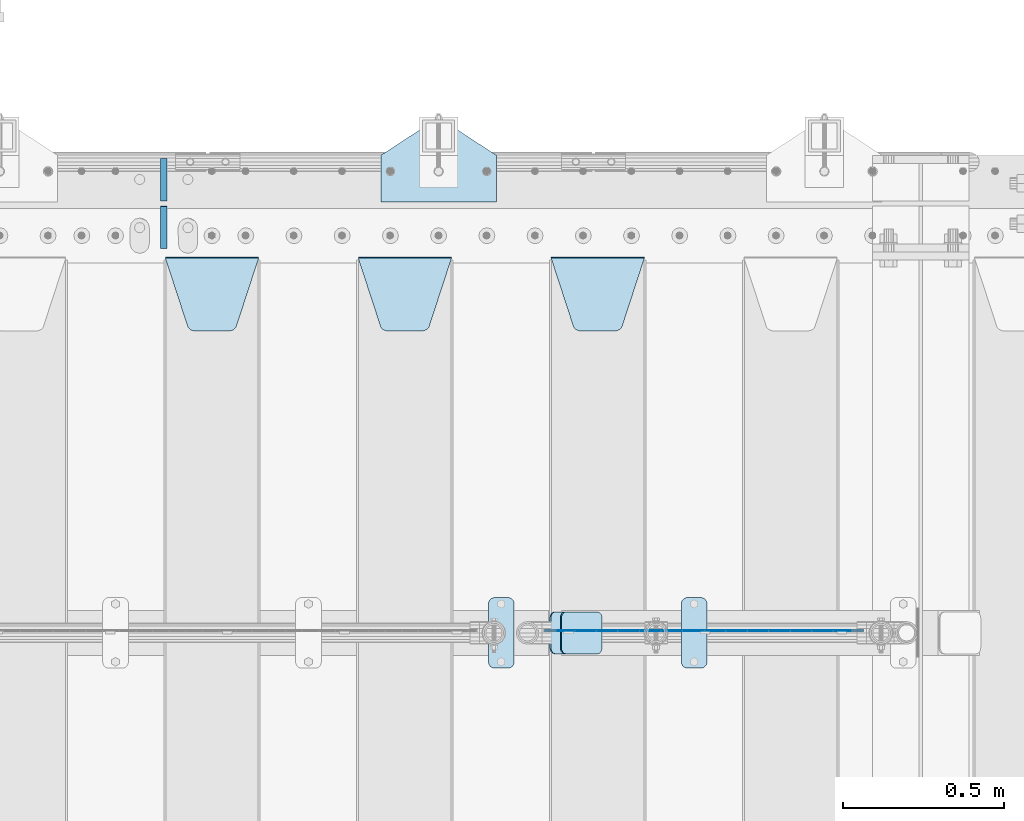
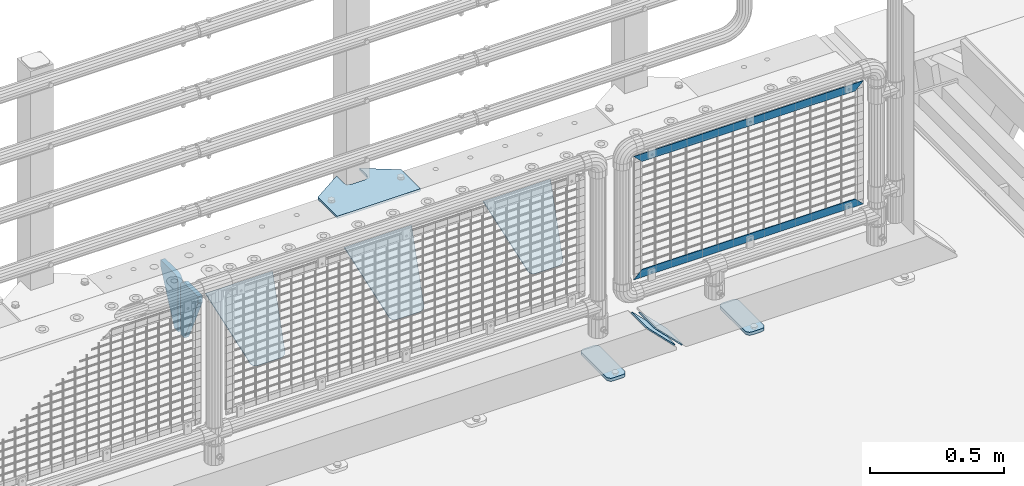
# One storey, part 202 of 219: 12 plates.
"""IFC2X3 building model written with IfcOpenShell, lengths in millimetres."""

from ifc_helpers import new_model, si_unit, frame, origin_with_axes, place, context, subcontext, project, spatial, faceted_brep, material, type_object, element, save


model = new_model("IFC2X3")

# Units and contexts
model_context = context("Model", 3, precision=1e-05, world=origin_with_axes())
body_context = subcontext(model_context, "Body", "Model", "MODEL_VIEW")
ifc_project = project(units=[si_unit("LENGTHUNIT", "METRE", prefix="MILLI"), si_unit("AREAUNIT", "SQUARE_METRE"), si_unit("VOLUMEUNIT", "CUBIC_METRE"), si_unit("MASSUNIT", "GRAM", prefix="KILO"), si_unit("TIMEUNIT", "SECOND"), si_unit("PLANEANGLEUNIT", "RADIAN"), si_unit("SOLIDANGLEUNIT", "STERADIAN"), si_unit("THERMODYNAMICTEMPERATUREUNIT", "DEGREE_CELSIUS"), si_unit("LUMINOUSINTENSITYUNIT", "LUMEN")], contexts=[model_context])

# Site, building, storey
site_placement = place(None, origin_with_axes())
site = spatial("IfcSite", under=ifc_project, at=site_placement, CompositionType="ELEMENT")
building_placement = place(site_placement, origin_with_axes())
building = spatial("IfcBuilding", under=site, at=building_placement, Name="Standard", CompositionType="ELEMENT")
storey_placement = place(building_placement, origin_with_axes())
storey = spatial("IfcBuildingStorey", under=building, at=storey_placement, Name="Undefined", CompositionType="ELEMENT", Elevation=0.0)

# Plates
ifc_material_1 = material(Name="STEEL/S355N")
plate_type_1 = type_object("IfcPlateType", PredefinedType="NOTDEFINED")
plate_1_placement = place(storey_placement, frame((12405.0, 32831.767766956, -1.76776695296758), z_axis=(0.0, -0.707106781186547, -0.707106781186548), x_axis=(1.0, 0.0, 0.0)))
element("IfcPlate", 1, at=plate_1_placement, inside=storey, type_object=plate_type_1, material=ifc_material_1, context=body_context, shape_type="Brep", body=[
    faceted_brep([(0.0, -2.5, 0.0), (69.345504679477, -2.5, 300.171731424834), (69.345504679477, 2.49999999999636, 300.171731424831), (0.0, 2.5, 0.0), (70.9274061199576, -2.50000000000364, 304.8974424154), (70.9274061199576, 2.49999999999636, 304.8974424154), (73.3818627772307, -2.50000000000364, 309.234538108532), (73.3818627772307, 2.49999999999636, 309.234538108532), (76.6187032999569, -2.50000000000364, 313.023683126106), (76.6187032999569, 2.49999999999636, 313.023683126106), (80.5190132704993, -2.50000000000364, 316.125672595372), (80.5190132704993, 2.49999999999636, 316.125672595372), (84.9395038596831, -2.50000000000364, 318.426546230476), (84.9395038596831, 2.5, 318.426546230479), (89.7177759439237, -2.50000000000364, 319.841774983277), (89.7177759439237, 2.5, 319.841774983281), (94.6782862926502, -2.50000000000364, 320.319366455078), (94.6782862926502, 2.49999999999636, 320.319366455078), (195.32171370735, -2.50000000000364, 320.319366455078), (195.32171370735, 2.49999999999636, 320.319366455078), (200.282224056076, -2.50000000000364, 319.841774983277), (200.282224056076, 2.5, 319.841774983281), (205.060496140317, -2.50000000000364, 318.426546230476), (205.060496140317, 2.49999999999636, 318.426546230476), (209.480986729501, -2.50000000000364, 316.125672595372), (209.480986729501, 2.49999999999636, 316.125672595372), (213.381296700043, -2.50000000000364, 313.023683126106), (213.381296700043, 2.49999999999272, 313.023683126106), (216.618137222769, -2.50000000000364, 309.234538108529), (216.618137222769, 2.49999999999636, 309.234538108525), (219.072593880042, -2.50000000000364, 304.8974424154), (219.072593880042, 2.49999999999636, 304.8974424154), (220.654495320523, -2.5, 300.171731424834), (220.654495320523, 2.49999999999636, 300.171731424831), (290.0, -2.50000000000364, 3.63797880709171e-12), (290.0, 2.49999999999636, 0.0)], [[[0, 1, 2, 3]], [[1, 4, 5, 2]], [[4, 6, 7, 5]], [[6, 8, 9, 7]], [[8, 10, 11, 9]], [[10, 12, 13, 11]], [[12, 14, 15, 13]], [[14, 16, 17, 15]], [[16, 18, 19, 17]], [[18, 20, 21, 19]], [[20, 22, 23, 21]], [[22, 24, 25, 23]], [[24, 26, 27, 25]], [[26, 28, 29, 27]], [[28, 30, 31, 29]], [[30, 32, 33, 31]], [[32, 34, 35, 33]], [[34, 0, 3, 35]], [[5, 7, 9, 11, 13, 15, 17, 19, 21, 23, 25, 27, 29, 31, 33, 35, 3, 2]], [[34, 32, 30, 28, 26, 24, 22, 20, 18, 16, 14, 12, 10, 8, 6, 4, 1, 0]]]),
])
plate_2_placement = place(storey_placement, frame((11805.0, 32831.767766956, -1.76776695296758), z_axis=(0.0, -0.707106781186547, -0.707106781186548), x_axis=(1.0, 0.0, 0.0)))
element("IfcPlate", 2, at=plate_2_placement, inside=storey, type_object=plate_type_1, material=ifc_material_1, context=body_context, shape_type="Brep", body=[
    faceted_brep([(0.0, -2.5, 0.0), (69.345504679477, -2.5, 300.171731424834), (69.345504679477, 2.49999999999636, 300.171731424831), (0.0, 2.5, 0.0), (70.9274061199576, -2.50000000000364, 304.8974424154), (70.9274061199576, 2.49999999999636, 304.8974424154), (73.3818627772307, -2.50000000000364, 309.234538108532), (73.3818627772307, 2.49999999999636, 309.234538108532), (76.6187032999569, -2.50000000000364, 313.023683126106), (76.6187032999569, 2.49999999999636, 313.023683126106), (80.5190132704993, -2.50000000000364, 316.125672595372), (80.5190132704993, 2.49999999999636, 316.125672595372), (84.9395038596831, -2.50000000000364, 318.426546230476), (84.9395038596831, 2.5, 318.426546230479), (89.7177759439237, -2.50000000000364, 319.841774983277), (89.7177759439237, 2.5, 319.841774983281), (94.6782862926502, -2.50000000000364, 320.319366455078), (94.6782862926502, 2.49999999999636, 320.319366455078), (195.32171370735, -2.50000000000364, 320.319366455078), (195.32171370735, 2.49999999999636, 320.319366455078), (200.282224056076, -2.50000000000364, 319.841774983277), (200.282224056076, 2.5, 319.841774983281), (205.060496140317, -2.50000000000364, 318.426546230476), (205.060496140317, 2.49999999999636, 318.426546230476), (209.480986729501, -2.50000000000364, 316.125672595372), (209.480986729501, 2.49999999999636, 316.125672595372), (213.381296700043, -2.50000000000364, 313.023683126106), (213.381296700043, 2.49999999999272, 313.023683126106), (216.618137222769, -2.50000000000364, 309.234538108529), (216.618137222769, 2.49999999999636, 309.234538108525), (219.072593880042, -2.50000000000364, 304.8974424154), (219.072593880042, 2.49999999999636, 304.8974424154), (220.654495320523, -2.5, 300.171731424834), (220.654495320523, 2.49999999999636, 300.171731424831), (290.0, -2.50000000000364, 3.63797880709171e-12), (290.0, 2.49999999999636, 0.0)], [[[0, 1, 2, 3]], [[1, 4, 5, 2]], [[4, 6, 7, 5]], [[6, 8, 9, 7]], [[8, 10, 11, 9]], [[10, 12, 13, 11]], [[12, 14, 15, 13]], [[14, 16, 17, 15]], [[16, 18, 19, 17]], [[18, 20, 21, 19]], [[20, 22, 23, 21]], [[22, 24, 25, 23]], [[24, 26, 27, 25]], [[26, 28, 29, 27]], [[28, 30, 31, 29]], [[30, 32, 33, 31]], [[32, 34, 35, 33]], [[34, 0, 3, 35]], [[5, 7, 9, 11, 13, 15, 17, 19, 21, 23, 25, 27, 29, 31, 33, 35, 3, 2]], [[34, 32, 30, 28, 26, 24, 22, 20, 18, 16, 14, 12, 10, 8, 6, 4, 1, 0]]]),
])
plate_3_placement = place(storey_placement, frame((11205.0, 32831.767766956, -1.76776695296758), z_axis=(0.0, -0.707106781186547, -0.707106781186548), x_axis=(1.0, 0.0, 0.0)))
element("IfcPlate", 3, at=plate_3_placement, inside=storey, type_object=plate_type_1, material=ifc_material_1, context=body_context, shape_type="Brep", body=[
    faceted_brep([(0.0, -2.5, 0.0), (69.345504679477, -2.5, 300.171731424834), (69.345504679477, 2.49999999999636, 300.171731424831), (0.0, 2.5, 0.0), (70.9274061199576, -2.50000000000364, 304.8974424154), (70.9274061199576, 2.49999999999636, 304.8974424154), (73.3818627772307, -2.50000000000364, 309.234538108532), (73.3818627772307, 2.49999999999636, 309.234538108532), (76.6187032999569, -2.50000000000364, 313.023683126106), (76.6187032999569, 2.49999999999636, 313.023683126106), (80.5190132704993, -2.50000000000364, 316.125672595372), (80.5190132704993, 2.49999999999636, 316.125672595372), (84.9395038596831, -2.50000000000364, 318.426546230476), (84.9395038596831, 2.5, 318.426546230479), (89.7177759439237, -2.50000000000364, 319.841774983277), (89.7177759439237, 2.5, 319.841774983281), (94.6782862926502, -2.50000000000364, 320.319366455078), (94.6782862926502, 2.49999999999636, 320.319366455078), (195.32171370735, -2.50000000000364, 320.319366455078), (195.32171370735, 2.49999999999636, 320.319366455078), (200.282224056076, -2.50000000000364, 319.841774983277), (200.282224056076, 2.5, 319.841774983281), (205.060496140317, -2.50000000000364, 318.426546230476), (205.060496140317, 2.49999999999636, 318.426546230476), (209.480986729501, -2.50000000000364, 316.125672595372), (209.480986729501, 2.49999999999636, 316.125672595372), (213.381296700043, -2.50000000000364, 313.023683126106), (213.381296700043, 2.49999999999272, 313.023683126106), (216.618137222769, -2.50000000000364, 309.234538108529), (216.618137222769, 2.49999999999636, 309.234538108525), (219.072593880042, -2.50000000000364, 304.8974424154), (219.072593880042, 2.49999999999636, 304.8974424154), (220.654495320523, -2.5, 300.171731424834), (220.654495320523, 2.49999999999636, 300.171731424831), (290.0, -2.50000000000364, 3.63797880709171e-12), (290.0, 2.49999999999636, 0.0)], [[[0, 1, 2, 3]], [[1, 4, 5, 2]], [[4, 6, 7, 5]], [[6, 8, 9, 7]], [[8, 10, 11, 9]], [[10, 12, 13, 11]], [[12, 14, 15, 13]], [[14, 16, 17, 15]], [[16, 18, 19, 17]], [[18, 20, 21, 19]], [[20, 22, 23, 21]], [[22, 24, 25, 23]], [[24, 26, 27, 25]], [[26, 28, 29, 27]], [[28, 30, 31, 29]], [[30, 32, 33, 31]], [[32, 34, 35, 33]], [[34, 0, 3, 35]], [[5, 7, 9, 11, 13, 15, 17, 19, 21, 23, 25, 27, 29, 31, 33, 35, 3, 2]], [[34, 32, 30, 28, 26, 24, 22, 20, 18, 16, 14, 12, 10, 8, 6, 4, 1, 0]]]),
])
ifc_material_2 = material(Name="Misc_Undefined")
plate_type_2 = type_object("IfcPlateType", PredefinedType="NOTDEFINED")
plate_4_placement = place(storey_placement, frame((12420.1100003336, 31670.4999883292, 386.520006105207), z_axis=(0.707106781186548, 0.0, -0.707106781186548), x_axis=(-0.707106781186548, 0.0, -0.707106781186548)))
element("IfcPlate", 4, at=plate_4_placement, inside=storey, type_object=plate_type_2, material=ifc_material_2, context=body_context, shape_type="Brep", body=[
    faceted_brep([(0.0, -1.5, -5.6843418860808e-14), (-651.52105712893, -1.5, 651.521179199219), (-651.521057128928, 1.49999999999636, 651.521179199219), (0.0, 1.5, -5.6843418860808e-14), (-651.52105712893, -1.5, 701.018676757811), (-651.521057128932, 1.5, 701.018676757811), (49.4974975585938, -1.5, 2.36468622460961e-11), (49.4974784851038, 1.5, -4.91127138957381e-11)], [[[0, 1, 2, 3]], [[1, 4, 5, 2]], [[4, 6, 7, 5]], [[6, 0, 3, 7]], [[5, 7, 3, 2]], [[6, 4, 1, 0]]]),
])
plate_5_placement = place(storey_placement, frame((13376.4999993967, 31670.4997837706, 914.520000514845), z_axis=(-0.707106781186548, 0.0, 0.707106781186548), x_axis=(-0.707106781186548, 0.0, -0.707106781186548)))
element("IfcPlate", 5, at=plate_5_placement, inside=storey, type_object=plate_type_2, material=ifc_material_2, context=body_context, shape_type="Brep", body=[
    faceted_brep([(0.0, -1.5, -5.6843418860808e-14), (701.018554687525, -1.50000000000728, 701.018615722655), (701.018554687524, 1.49999999999272, 701.018615722654), (0.0, 1.5, -5.6843418860808e-14), (701.018554687524, -1.50000000000728, 651.521118164063), (701.018554687524, 1.49999999999272, 651.521118164062), (49.4974975585938, -1.5, 2.36468622460961e-11), (49.4974784851038, 1.5, -4.91127138957381e-11)], [[[0, 1, 2, 3]], [[1, 4, 5, 2]], [[4, 6, 7, 5]], [[6, 0, 3, 7]], [[5, 7, 3, 2]], [[6, 4, 1, 0]]]),
])
plate_type_3 = type_object("IfcPlateType", PredefinedType="NOTDEFINED")
for number, where, z_axis, x_axis in (
    (6, (11200.0, 33140.0, -30.0), (0.0, 0.0, -1.0), (0.0, -1.0, 0.0)),
    (7, (11200.0, 32860.0, -30.0), (0.0, 0.0, -1.0), (0.0, 1.0, 0.0)),
):
    element("IfcPlate", number, at=place(storey_placement, frame(where, z_axis=z_axis, x_axis=x_axis)), inside=storey, type_object=plate_type_3, material=ifc_material_1, context=body_context, shape_type="Brep", body=[
        faceted_brep([(0.0, -10.0, 0.0), (0.0, -10.0, 30.0), (0.0, 10.0, 30.0), (0.0, 10.0, 0.0), (102.0, -10.0, 250.0), (102.0, 10.0, 250.0), (132.0, -10.0, 250.0), (132.0, 10.0, 250.0), (132.0, -10.0, 30.0), (132.0, 10.0, 30.0), (131.544232590368, -10.0, 24.790554669992), (131.544232590368, 10.0, 24.790554669992), (130.190778623579, -10.0, 19.7393957002299), (130.190778623579, 10.0, 19.7393957002299), (127.980762113533, -10.0, 15.0), (127.980762113533, 10.0, 15.0), (124.98133329357, -10.0, 10.7163717094038), (124.98133329357, 10.0, 10.7163717094038), (121.283628290596, -10.0, 7.01866670643062), (121.283628290596, 10.0, 7.01866670643062), (117.0, -10.0, 4.01923788646684), (117.0, 10.0, 4.01923788646684), (112.260604299769, -10.0, 1.80922137642278), (112.260604299769, 10.0, 1.80922137642278), (107.209445330009, -10.0, 0.455767409633722), (107.209445330009, 10.0, 0.455767409633722), (102.0, -10.0, 0.0), (102.0, 10.0, 0.0)], [[[0, 1, 2, 3]], [[1, 4, 5, 2]], [[4, 6, 7, 5]], [[6, 8, 9, 7]], [[8, 10, 11, 9]], [[10, 12, 13, 11]], [[12, 14, 15, 13]], [[14, 16, 17, 15]], [[16, 18, 19, 17]], [[18, 20, 21, 19]], [[20, 22, 23, 21]], [[22, 24, 25, 23]], [[24, 26, 27, 25]], [[26, 0, 3, 27]], [[5, 7, 9, 11, 13, 15, 17, 19, 21, 23, 25, 27, 3, 2]], [[26, 24, 22, 20, 18, 16, 14, 12, 10, 8, 6, 4, 1, 0]]]),
    ])
ifc_material_3 = material(Name="STEEL/S355J2")
plate_type_4 = type_object("IfcPlateType", PredefinedType="NOTDEFINED")
plate_6_placement = place(storey_placement, frame((12210.0, 31774.5, 21.0199999999977), z_axis=(1.0, 0.0, 0.0), x_axis=(0.0, -1.0, 0.0)))
element("IfcPlate", 8, at=plate_6_placement, inside=storey, type_object=plate_type_4, material=ifc_material_3, context=body_context, shape_type="Brep", body=[
    faceted_brep([(0.0, -7.0, 20.0), (0.0, -7.0, 60.0), (0.0, 7.0, 60.0), (0.0, 7.0, 20.0), (0.384294391937146, -7.0, 63.9018064403226), (0.384294391937146, 7.0, 63.9018064403226), (1.52240934977453, -7.0, 67.6536686473009), (1.52240934977453, 7.0, 67.6536686473009), (3.37060775395003, -7.0, 71.1114046603925), (3.37060775395003, 7.0, 71.1114046603925), (5.8578643762703, -7.0, 74.1421356237315), (5.8578643762703, 7.0, 74.1421356237315), (8.88859533960931, -7.0, 76.6293922460518), (8.88859533960931, 7.0, 76.6293922460518), (12.3463313526991, -7.0, 78.4775906502255), (12.3463313526991, 7.0, 78.4775906502255), (16.0981935596792, -7.0, 79.6157056080647), (16.0981935596792, 7.0, 79.6157056080647), (20.0, -7.0, 80.0), (20.0, 7.0, 80.0), (200.0, -7.0, 80.0), (200.0, 7.0, 80.0), (203.901806440321, -7.0, 79.6157056080647), (203.901806440321, 7.0, 79.6157056080647), (207.653668647301, -7.0, 78.4775906502255), (207.653668647301, 7.0, 78.4775906502255), (211.111404660391, -7.0, 76.6293922460518), (211.111404660391, 7.0, 76.6293922460518), (214.14213562373, -7.0, 74.1421356237315), (214.14213562373, 7.0, 74.1421356237315), (216.62939224605, -7.0, 71.1114046603925), (216.62939224605, 7.0, 71.1114046603925), (218.477590650225, -7.0, 67.6536686473009), (218.477590650225, 7.0, 67.6536686473009), (219.615705608063, -7.0, 63.9018064403226), (219.615705608063, 7.0, 63.9018064403226), (220.0, -7.0, 60.0), (220.0, 7.0, 60.0), (220.0, -7.0, 20.0), (220.0, 7.0, 20.0), (219.615705608063, -7.0, 16.0981935596774), (219.615705608063, 7.0, 16.0981935596774), (218.477590650225, -7.0, 12.3463313526991), (218.477590650225, 7.0, 12.3463313526991), (216.62939224605, -7.0, 8.88859533960749), (216.62939224605, 7.0, 8.88859533960749), (214.14213562373, -7.0, 5.85786437626848), (214.14213562373, 7.0, 5.85786437626848), (211.111404660391, -7.0, 3.37060775394821), (211.111404660391, 7.0, 3.37060775394821), (207.653668647301, -7.0, 1.52240934977453), (207.653668647301, 7.0, 1.52240934977453), (203.901806440321, -7.0, 0.384294391935327), (203.901806440321, 7.0, 0.384294391935327), (200.0, -7.0, 0.0), (200.0, 7.0, 0.0), (20.0, -7.0, 0.0), (20.0, 7.0, 0.0), (16.0981935596792, -7.0, 0.384294391935327), (16.0981935596792, 7.0, 0.384294391935327), (12.3463313526991, -7.0, 1.52240934977453), (12.3463313526991, 7.0, 1.52240934977453), (8.88859533960931, -7.0, 3.37060775394821), (8.88859533960931, 7.0, 3.37060775394821), (5.8578643762703, -7.0, 5.85786437626848), (5.8578643762703, 7.0, 5.85786437626848), (3.37060775395003, -7.0, 8.88859533960749), (3.37060775395003, 7.0, 8.88859533960749), (1.52240934977453, -7.0, 12.3463313526991), (1.52240934977453, 7.0, 12.3463313526991), (0.384294391937146, -7.0, 16.0981935596774), (0.384294391937146, 7.0, 16.0981935596774)], [[[0, 1, 2, 3]], [[1, 4, 5, 2]], [[4, 6, 7, 5]], [[6, 8, 9, 7]], [[8, 10, 11, 9]], [[10, 12, 13, 11]], [[12, 14, 15, 13]], [[14, 16, 17, 15]], [[16, 18, 19, 17]], [[18, 20, 21, 19]], [[20, 22, 23, 21]], [[22, 24, 25, 23]], [[24, 26, 27, 25]], [[26, 28, 29, 27]], [[28, 30, 31, 29]], [[30, 32, 33, 31]], [[32, 34, 35, 33]], [[34, 36, 37, 35]], [[36, 38, 39, 37]], [[38, 40, 41, 39]], [[40, 42, 43, 41]], [[42, 44, 45, 43]], [[44, 46, 47, 45]], [[46, 48, 49, 47]], [[48, 50, 51, 49]], [[50, 52, 53, 51]], [[52, 54, 55, 53]], [[54, 56, 57, 55]], [[56, 58, 59, 57]], [[58, 60, 61, 59]], [[60, 62, 63, 61]], [[62, 64, 65, 63]], [[64, 66, 67, 65]], [[66, 68, 69, 67]], [[68, 70, 71, 69]], [[70, 0, 3, 71]], [[5, 7, 9, 11, 13, 15, 17, 19, 21, 23, 25, 27, 29, 31, 33, 35, 37, 39, 41, 43, 45, 47, 49, 51, 53, 55, 57, 59, 61, 63, 65, 67, 69, 71, 3, 2]], [[70, 68, 66, 64, 62, 60, 58, 56, 54, 52, 50, 48, 46, 44, 42, 40, 38, 36, 34, 32, 30, 28, 26, 24, 22, 20, 18, 16, 14, 12, 10, 8, 6, 4, 1, 0]]]),
])
plate_7_placement = place(storey_placement, frame((12810.0, 31774.5, 21.0199999999977), z_axis=(1.0, 0.0, 0.0), x_axis=(0.0, -1.0, 0.0)))
element("IfcPlate", 9, at=plate_7_placement, inside=storey, type_object=plate_type_4, material=ifc_material_3, context=body_context, shape_type="Brep", body=[
    faceted_brep([(0.0, -7.0, 20.0), (0.0, -7.0, 60.0), (0.0, 7.0, 60.0), (0.0, 7.0, 20.0), (0.384294391937146, -7.0, 63.9018064403226), (0.384294391937146, 7.0, 63.9018064403226), (1.52240934977453, -7.0, 67.6536686473009), (1.52240934977453, 7.0, 67.6536686473009), (3.37060775395003, -7.0, 71.1114046603925), (3.37060775395003, 7.0, 71.1114046603925), (5.8578643762703, -7.0, 74.1421356237315), (5.8578643762703, 7.0, 74.1421356237315), (8.88859533960931, -7.0, 76.6293922460518), (8.88859533960931, 7.0, 76.6293922460518), (12.3463313526991, -7.0, 78.4775906502255), (12.3463313526991, 7.0, 78.4775906502255), (16.0981935596792, -7.0, 79.6157056080647), (16.0981935596792, 7.0, 79.6157056080647), (20.0, -7.0, 80.0), (20.0, 7.0, 80.0), (200.0, -7.0, 80.0), (200.0, 7.0, 80.0), (203.901806440321, -7.0, 79.6157056080647), (203.901806440321, 7.0, 79.6157056080647), (207.653668647301, -7.0, 78.4775906502255), (207.653668647301, 7.0, 78.4775906502255), (211.111404660391, -7.0, 76.6293922460518), (211.111404660391, 7.0, 76.6293922460518), (214.14213562373, -7.0, 74.1421356237315), (214.14213562373, 7.0, 74.1421356237315), (216.62939224605, -7.0, 71.1114046603925), (216.62939224605, 7.0, 71.1114046603925), (218.477590650225, -7.0, 67.6536686473009), (218.477590650225, 7.0, 67.6536686473009), (219.615705608063, -7.0, 63.9018064403226), (219.615705608063, 7.0, 63.9018064403226), (220.0, -7.0, 60.0), (220.0, 7.0, 60.0), (220.0, -7.0, 20.0), (220.0, 7.0, 20.0), (219.615705608063, -7.0, 16.0981935596774), (219.615705608063, 7.0, 16.0981935596774), (218.477590650225, -7.0, 12.3463313526991), (218.477590650225, 7.0, 12.3463313526991), (216.62939224605, -7.0, 8.88859533960749), (216.62939224605, 7.0, 8.88859533960749), (214.14213562373, -7.0, 5.85786437626848), (214.14213562373, 7.0, 5.85786437626848), (211.111404660391, -7.0, 3.37060775394821), (211.111404660391, 7.0, 3.37060775394821), (207.653668647301, -7.0, 1.52240934977453), (207.653668647301, 7.0, 1.52240934977453), (203.901806440321, -7.0, 0.384294391935327), (203.901806440321, 7.0, 0.384294391935327), (200.0, -7.0, 0.0), (200.0, 7.0, 0.0), (20.0, -7.0, 0.0), (20.0, 7.0, 0.0), (16.0981935596792, -7.0, 0.384294391935327), (16.0981935596792, 7.0, 0.384294391935327), (12.3463313526991, -7.0, 1.52240934977453), (12.3463313526991, 7.0, 1.52240934977453), (8.88859533960931, -7.0, 3.37060775394821), (8.88859533960931, 7.0, 3.37060775394821), (5.8578643762703, -7.0, 5.85786437626848), (5.8578643762703, 7.0, 5.85786437626848), (3.37060775395003, -7.0, 8.88859533960749), (3.37060775395003, 7.0, 8.88859533960749), (1.52240934977453, -7.0, 12.3463313526991), (1.52240934977453, 7.0, 12.3463313526991), (0.384294391937146, -7.0, 16.0981935596774), (0.384294391937146, 7.0, 16.0981935596774)], [[[0, 1, 2, 3]], [[1, 4, 5, 2]], [[4, 6, 7, 5]], [[6, 8, 9, 7]], [[8, 10, 11, 9]], [[10, 12, 13, 11]], [[12, 14, 15, 13]], [[14, 16, 17, 15]], [[16, 18, 19, 17]], [[18, 20, 21, 19]], [[20, 22, 23, 21]], [[22, 24, 25, 23]], [[24, 26, 27, 25]], [[26, 28, 29, 27]], [[28, 30, 31, 29]], [[30, 32, 33, 31]], [[32, 34, 35, 33]], [[34, 36, 37, 35]], [[36, 38, 39, 37]], [[38, 40, 41, 39]], [[40, 42, 43, 41]], [[42, 44, 45, 43]], [[44, 46, 47, 45]], [[46, 48, 49, 47]], [[48, 50, 51, 49]], [[50, 52, 53, 51]], [[52, 54, 55, 53]], [[54, 56, 57, 55]], [[56, 58, 59, 57]], [[58, 60, 61, 59]], [[60, 62, 63, 61]], [[62, 64, 65, 63]], [[64, 66, 67, 65]], [[66, 68, 69, 67]], [[68, 70, 71, 69]], [[70, 0, 3, 71]], [[5, 7, 9, 11, 13, 15, 17, 19, 21, 23, 25, 27, 29, 31, 33, 35, 37, 39, 41, 43, 45, 47, 49, 51, 53, 55, 57, 59, 61, 63, 65, 67, 69, 71, 3, 2]], [[70, 68, 66, 64, 62, 60, 58, 56, 54, 52, 50, 48, 46, 44, 42, 40, 38, 36, 34, 32, 30, 28, 26, 24, 22, 20, 18, 16, 14, 12, 10, 8, 6, 4, 1, 0]]]),
])
plate_type_5 = type_object("IfcPlateType", PredefinedType="NOTDEFINED")
plate_8_placement = place(storey_placement, frame((12402.192418479, 31729.5, 166.254400376569), z_axis=(0.707410512925778, 0.0, -0.706802918925841), x_axis=(0.0, -1.0, 0.0)))
element("IfcPlate", 10, at=plate_8_placement, inside=storey, type_object=plate_type_5, material=ifc_material_3, context=body_context, shape_type="Brep", body=[
    faceted_brep([(0.0, -2.5, 20.0), (0.0, -2.5, 158.926651000977), (0.0, 2.5, 158.926651000977), (0.0, 2.49999999999818, 20.0), (0.384294391937146, -2.5, 162.828457441299), (0.384294391937146, 2.5, 162.828457441299), (1.52240934977453, -2.5, 166.580319648279), (1.52240934977453, 2.5, 166.580319648279), (3.37060775395003, -2.5, 170.038055661367), (3.37060775395003, 2.5, 170.038055661367), (5.8578643762703, -2.5, 173.068786624706), (5.8578643762703, 2.5, 173.068786624706), (8.88859533960931, -2.5, 175.556043247028), (8.88859533960931, 2.5, 175.556043247027), (12.3463313526991, -2.49999999999818, 177.404241651202), (12.3463313526991, 2.5, 177.404241651202), (16.0981935596792, -2.5, 178.542356609041), (16.0981935596792, 2.5, 178.542356609041), (20.0, -2.5, 178.926651000977), (20.0, 2.5, 178.926651000975), (110.0, -2.5, 178.926651000977), (110.0, 2.5, 178.926651000975), (113.901806440321, -2.5, 178.542356609041), (113.901806440321, 2.5, 178.542356609041), (117.653668647301, -2.49999999999818, 177.404241651202), (117.653668647301, 2.5, 177.404241651202), (121.111404660391, -2.5, 175.556043247028), (121.111404660391, 2.5, 175.556043247027), (124.14213562373, -2.5, 173.068786624706), (124.14213562373, 2.5, 173.068786624706), (126.62939224605, -2.5, 170.038055661367), (126.62939224605, 2.5, 170.038055661367), (128.477590650225, -2.5, 166.580319648279), (128.477590650225, 2.5, 166.580319648279), (129.615705608063, -2.5, 162.828457441299), (129.615705608063, 2.5, 162.828457441299), (130.0, -2.5, 158.926651000977), (130.0, 2.5, 158.926651000977), (130.0, -2.5, 20.0), (130.0, 2.49999999999818, 20.0), (129.615705608063, -2.50000000000182, 16.0981935596774), (129.615705608063, 2.50000000000182, 16.0981935596774), (128.477590650225, -2.5, 12.3463313526972), (128.477590650225, 2.5, 12.3463313526991), (126.62939224605, -2.5, 8.88859533960749), (126.62939224605, 2.50000000000182, 8.88859533960749), (124.14213562373, -2.50000000000182, 5.85786437626848), (124.14213562373, 2.5, 5.85786437626848), (121.111404660391, -2.5, 3.37060775394821), (121.111404660391, 2.5, 3.37060775395003), (117.653668647301, -2.5, 1.52240934977453), (117.653668647301, 2.5, 1.52240934977272), (113.901806440321, -2.5, 0.384294391935327), (113.901806440321, 2.5, 0.384294391935327), (110.0, -2.5, -1.81898940354586e-12), (110.0, 2.49999999999818, 0.0), (20.0, -2.5, -1.81898940354586e-12), (20.0, 2.49999999999818, 0.0), (16.0981935596792, -2.5, 0.384294391935327), (16.0981935596792, 2.5, 0.384294391935327), (12.3463313526991, -2.5, 1.52240934977453), (12.3463313526991, 2.5, 1.52240934977272), (8.88859533960931, -2.5, 3.37060775394821), (8.88859533960931, 2.5, 3.37060775395003), (5.8578643762703, -2.50000000000182, 5.85786437626848), (5.8578643762703, 2.5, 5.85786437626848), (3.37060775395003, -2.5, 8.88859533960749), (3.37060775395003, 2.50000000000182, 8.88859533960749), (1.52240934977453, -2.5, 12.3463313526972), (1.52240934977453, 2.5, 12.3463313526991), (0.384294391937146, -2.50000000000182, 16.0981935596774), (0.384294391937146, 2.50000000000182, 16.0981935596774)], [[[0, 1, 2, 3]], [[1, 4, 5, 2]], [[4, 6, 7, 5]], [[6, 8, 9, 7]], [[8, 10, 11, 9]], [[10, 12, 13, 11]], [[12, 14, 15, 13]], [[14, 16, 17, 15]], [[16, 18, 19, 17]], [[18, 20, 21, 19]], [[20, 22, 23, 21]], [[22, 24, 25, 23]], [[24, 26, 27, 25]], [[26, 28, 29, 27]], [[28, 30, 31, 29]], [[30, 32, 33, 31]], [[32, 34, 35, 33]], [[34, 36, 37, 35]], [[36, 38, 39, 37]], [[38, 40, 41, 39]], [[40, 42, 43, 41]], [[42, 44, 45, 43]], [[44, 46, 47, 45]], [[46, 48, 49, 47]], [[48, 50, 51, 49]], [[50, 52, 53, 51]], [[52, 54, 55, 53]], [[54, 56, 57, 55]], [[56, 58, 59, 57]], [[58, 60, 61, 59]], [[60, 62, 63, 61]], [[62, 64, 65, 63]], [[64, 66, 67, 65]], [[66, 68, 69, 67]], [[68, 70, 71, 69]], [[70, 0, 3, 71]], [[5, 7, 9, 11, 13, 15, 17, 19, 21, 23, 25, 27, 29, 31, 33, 35, 37, 39, 41, 43, 45, 47, 49, 51, 53, 55, 57, 59, 61, 63, 65, 67, 69, 71, 3, 2]], [[70, 68, 66, 64, 62, 60, 58, 56, 54, 52, 50, 48, 46, 44, 42, 40, 38, 36, 34, 32, 30, 28, 26, 24, 22, 20, 18, 16, 14, 12, 10, 8, 6, 4, 1, 0]]]),
])
plate_9_placement = place(storey_placement, frame((12435.1214822168, 31729.5, 156.25145405626), z_axis=(0.707418377001897, 0.0, -0.706795048001896), x_axis=(0.0, -1.0, 0.0)))
element("IfcPlate", 11, at=plate_9_placement, inside=storey, type_object=plate_type_5, material=ifc_material_3, context=body_context, shape_type="Brep", body=[
    faceted_brep([(0.0, -2.5, 20.0), (0.0, -2.5, 158.926651000977), (0.0, 2.5, 158.926651000977), (0.0, 2.49999999999818, 20.0), (0.384294391937146, -2.5, 162.828457441299), (0.384294391937146, 2.5, 162.828457441299), (1.52240934977453, -2.5, 166.580319648279), (1.52240934977453, 2.5, 166.580319648279), (3.37060775395003, -2.5, 170.038055661367), (3.37060775395003, 2.5, 170.038055661367), (5.8578643762703, -2.5, 173.068786624706), (5.8578643762703, 2.5, 173.068786624706), (8.88859533960931, -2.5, 175.556043247028), (8.88859533960931, 2.5, 175.556043247027), (12.3463313526991, -2.49999999999818, 177.404241651202), (12.3463313526991, 2.5, 177.404241651202), (16.0981935596792, -2.5, 178.542356609041), (16.0981935596792, 2.5, 178.542356609041), (20.0, -2.5, 178.926651000977), (20.0, 2.5, 178.926651000975), (110.0, -2.5, 178.926651000977), (110.0, 2.5, 178.926651000975), (113.901806440321, -2.5, 178.542356609041), (113.901806440321, 2.5, 178.542356609041), (117.653668647301, -2.49999999999818, 177.404241651202), (117.653668647301, 2.5, 177.404241651202), (121.111404660391, -2.5, 175.556043247028), (121.111404660391, 2.5, 175.556043247027), (124.14213562373, -2.5, 173.068786624706), (124.14213562373, 2.5, 173.068786624706), (126.62939224605, -2.5, 170.038055661367), (126.62939224605, 2.5, 170.038055661367), (128.477590650225, -2.5, 166.580319648279), (128.477590650225, 2.5, 166.580319648279), (129.615705608063, -2.5, 162.828457441299), (129.615705608063, 2.5, 162.828457441299), (130.0, -2.5, 158.926651000977), (130.0, 2.5, 158.926651000977), (130.0, -2.5, 20.0), (130.0, 2.49999999999818, 20.0), (129.615705608063, -2.50000000000182, 16.0981935596774), (129.615705608063, 2.50000000000182, 16.0981935596774), (128.477590650225, -2.5, 12.3463313526972), (128.477590650225, 2.5, 12.3463313526991), (126.62939224605, -2.5, 8.88859533960749), (126.62939224605, 2.50000000000182, 8.88859533960749), (124.14213562373, -2.50000000000182, 5.85786437626848), (124.14213562373, 2.5, 5.85786437626848), (121.111404660391, -2.5, 3.37060775394821), (121.111404660391, 2.5, 3.37060775395003), (117.653668647301, -2.5, 1.52240934977453), (117.653668647301, 2.5, 1.52240934977272), (113.901806440321, -2.5, 0.384294391935327), (113.901806440321, 2.5, 0.384294391935327), (110.0, -2.5, -1.81898940354586e-12), (110.0, 2.49999999999818, 0.0), (20.0, -2.5, -1.81898940354586e-12), (20.0, 2.49999999999818, 0.0), (16.0981935596792, -2.5, 0.384294391935327), (16.0981935596792, 2.5, 0.384294391935327), (12.3463313526991, -2.5, 1.52240934977453), (12.3463313526991, 2.5, 1.52240934977272), (8.88859533960931, -2.5, 3.37060775394821), (8.88859533960931, 2.5, 3.37060775395003), (5.8578643762703, -2.50000000000182, 5.85786437626848), (5.8578643762703, 2.5, 5.85786437626848), (3.37060775395003, -2.5, 8.88859533960749), (3.37060775395003, 2.50000000000182, 8.88859533960749), (1.52240934977453, -2.5, 12.3463313526972), (1.52240934977453, 2.5, 12.3463313526991), (0.384294391937146, -2.50000000000182, 16.0981935596774), (0.384294391937146, 2.50000000000182, 16.0981935596774)], [[[0, 1, 2, 3]], [[1, 4, 5, 2]], [[4, 6, 7, 5]], [[6, 8, 9, 7]], [[8, 10, 11, 9]], [[10, 12, 13, 11]], [[12, 14, 15, 13]], [[14, 16, 17, 15]], [[16, 18, 19, 17]], [[18, 20, 21, 19]], [[20, 22, 23, 21]], [[22, 24, 25, 23]], [[24, 26, 27, 25]], [[26, 28, 29, 27]], [[28, 30, 31, 29]], [[30, 32, 33, 31]], [[32, 34, 35, 33]], [[34, 36, 37, 35]], [[36, 38, 39, 37]], [[38, 40, 41, 39]], [[40, 42, 43, 41]], [[42, 44, 45, 43]], [[44, 46, 47, 45]], [[46, 48, 49, 47]], [[48, 50, 51, 49]], [[50, 52, 53, 51]], [[52, 54, 55, 53]], [[54, 56, 57, 55]], [[56, 58, 59, 57]], [[58, 60, 61, 59]], [[60, 62, 63, 61]], [[62, 64, 65, 63]], [[64, 66, 67, 65]], [[66, 68, 69, 67]], [[68, 70, 71, 69]], [[70, 0, 3, 71]], [[5, 7, 9, 11, 13, 15, 17, 19, 21, 23, 25, 27, 29, 31, 33, 35, 37, 39, 41, 43, 45, 47, 49, 51, 53, 55, 57, 59, 61, 63, 65, 67, 69, 71, 3, 2]], [[70, 68, 66, 64, 62, 60, 58, 56, 54, 52, 50, 48, 46, 44, 42, 40, 38, 36, 34, 32, 30, 28, 26, 24, 22, 20, 18, 16, 14, 12, 10, 8, 6, 4, 1, 0]]]),
])
plate_type_6 = type_object("IfcPlateType", PredefinedType="NOTDEFINED")
plate_10_placement = place(storey_placement, frame((11875.0, 33005.0, 5.00000000004911), z_axis=(0.0, 1.0, 0.0), x_axis=(1.0, 0.0, 0.0)))
element("IfcPlate", 12, at=plate_10_placement, inside=storey, type_object=plate_type_6, material=ifc_material_3, context=body_context, shape_type="Brep", body=[
    faceted_brep([(0.0, -5.0, 0.0), (2.31396552408114e-06, -5.0, 145.0), (2.31396552408114e-06, 5.0, 145.0), (0.0, 5.0, 0.0), (130.0, -5.0, 230.0), (130.0, 5.0, 230.0), (130.0, -5.0, 180.0), (130.0, 5.0, 180.0), (130.48036798992, -5.0, 175.122741949599), (130.48036798992, 5.0, 175.122741949599), (131.903011687218, -5.0, 170.432914190875), (131.903011687218, 5.0, 170.432914190875), (134.213259692437, -5.0, 166.110744174512), (134.213259692437, 5.0, 166.110744174512), (137.322330470337, -5.0, 162.322330470335), (137.322330470337, 5.0, 162.322330470335), (141.11074417451, -5.0, 159.213259692435), (141.11074417451, 5.0, 159.213259692435), (145.432914190873, -5.0, 156.903011687216), (145.432914190873, 5.0, 156.903011687216), (150.122741949597, -5.0, 155.48036798992), (150.122741949597, 5.0, 155.48036798992), (155.0, -5.0, 155.0), (155.0, 5.0, 155.0), (205.0, -5.0, 155.0), (205.0, 5.0, 155.0), (209.877258050403, -5.0, 155.48036798992), (209.877258050403, 5.0, 155.48036798992), (214.567085809127, -5.0, 156.903011687216), (214.567085809127, 5.0, 156.903011687216), (218.88925582549, -5.0, 159.213259692435), (218.88925582549, 5.0, 159.213259692435), (222.677669529663, -5.0, 162.322330470335), (222.677669529663, 5.0, 162.322330470335), (225.786740307563, -5.0, 166.110744174512), (225.786740307563, 5.0, 166.110744174512), (228.096988312782, -5.0, 170.432914190875), (228.096988312782, 5.0, 170.432914190875), (229.51963201008, -5.0, 175.122741949599), (229.51963201008, 5.0, 175.122741949599), (230.0, -5.0, 180.0), (230.0, 5.0, 180.0), (230.0, -5.0, 230.0), (230.0, 5.0, 230.0), (360.0, -5.0, 145.0), (360.0, 5.0, 145.0), (360.0, -5.0, -7.27595761418343e-12), (360.0, 5.0, -7.27595761418343e-12)], [[[0, 1, 2, 3]], [[1, 4, 5, 2]], [[4, 6, 7, 5]], [[6, 8, 9, 7]], [[8, 10, 11, 9]], [[10, 12, 13, 11]], [[12, 14, 15, 13]], [[14, 16, 17, 15]], [[16, 18, 19, 17]], [[18, 20, 21, 19]], [[20, 22, 23, 21]], [[22, 24, 25, 23]], [[24, 26, 27, 25]], [[26, 28, 29, 27]], [[28, 30, 31, 29]], [[30, 32, 33, 31]], [[32, 34, 35, 33]], [[34, 36, 37, 35]], [[36, 38, 39, 37]], [[38, 40, 41, 39]], [[40, 42, 43, 41]], [[42, 44, 45, 43]], [[44, 46, 47, 45]], [[46, 0, 3, 47]], [[5, 7, 9, 11, 13, 15, 17, 19, 21, 23, 25, 27, 29, 31, 33, 35, 37, 39, 41, 43, 45, 47, 3, 2]], [[46, 44, 42, 40, 38, 36, 34, 32, 30, 28, 26, 24, 22, 20, 18, 16, 14, 12, 10, 8, 6, 4, 1, 0]]]),
])

save(model, "model.ifc")
